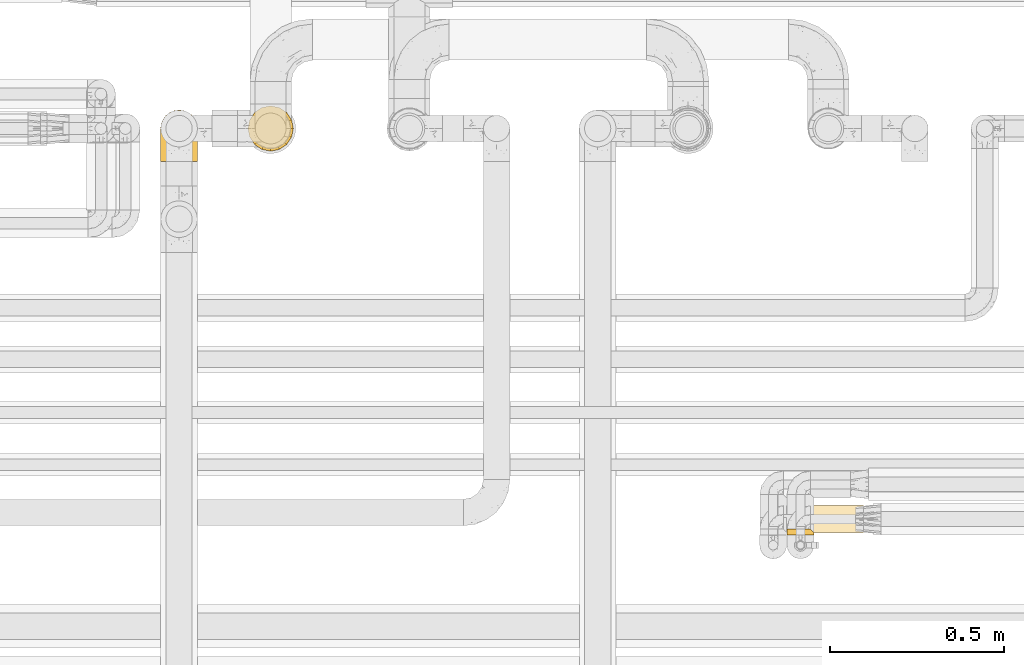
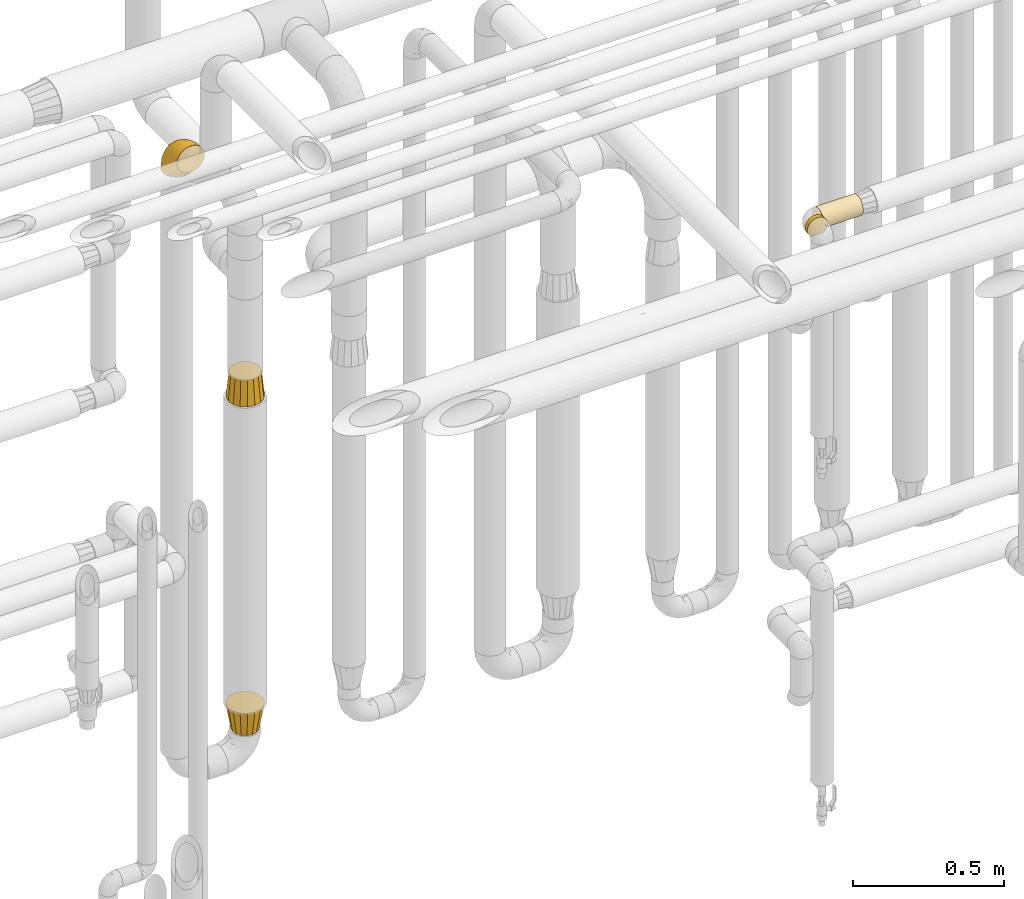
# One storey, part 463 of 827: 5 coverings.
"""IFC2X3 building model written with IfcOpenShell, lengths in millimetres."""

from ifc_helpers import new_model, entity, si_unit, converted_unit, derived_unit, direction, frame, origin, place, context, subcontext, project, spatial, faceted_brep, element, save


model = new_model("IFC2X3")

# Units and contexts
model_context = context("Model", 3, precision=0.01, world=origin(), true_north=direction((6.12303176911189e-17, 1.0)))
body_context = subcontext(model_context, "Body", "Model", "MODEL_VIEW")
ifc_project = project(units=[si_unit("LENGTHUNIT", "METRE", prefix="MILLI"), si_unit("AREAUNIT", "SQUARE_METRE"), si_unit("VOLUMEUNIT", "CUBIC_METRE"), converted_unit("PLANEANGLEUNIT", "DEGREE", entity("IfcRatioMeasure", 0.0174532925199433), si_unit("PLANEANGLEUNIT", "RADIAN"), dimensions=[0, 0, 0, 0, 0, 0, 0]), si_unit("MASSUNIT", "GRAM", prefix="KILO"), derived_unit("MASSDENSITYUNIT", [(si_unit("MASSUNIT", "GRAM", prefix="KILO"), 1), (si_unit("LENGTHUNIT", "METRE"), -3)]), derived_unit("MOMENTOFINERTIAUNIT", [(si_unit("LENGTHUNIT", "METRE"), 4)]), si_unit("TIMEUNIT", "SECOND"), si_unit("FREQUENCYUNIT", "HERTZ"), si_unit("THERMODYNAMICTEMPERATUREUNIT", "DEGREE_CELSIUS"), derived_unit("THERMALTRANSMITTANCEUNIT", [(si_unit("MASSUNIT", "GRAM", prefix="KILO"), 1), (si_unit("THERMODYNAMICTEMPERATUREUNIT", "KELVIN"), -1), (si_unit("TIMEUNIT", "SECOND"), -3)]), derived_unit("VOLUMETRICFLOWRATEUNIT", [(si_unit("LENGTHUNIT", "METRE"), 3), (si_unit("TIMEUNIT", "SECOND"), -1)]), derived_unit("MASSFLOWRATEUNIT", [(si_unit("MASSUNIT", "GRAM", prefix="KILO"), 1), (si_unit("TIMEUNIT", "SECOND"), -1)]), derived_unit("ROTATIONALFREQUENCYUNIT", [(si_unit("TIMEUNIT", "SECOND"), -1)]), si_unit("ELECTRICCURRENTUNIT", "AMPERE"), si_unit("ELECTRICVOLTAGEUNIT", "VOLT"), si_unit("POWERUNIT", "WATT"), si_unit("FORCEUNIT", "NEWTON", prefix="KILO"), si_unit("ILLUMINANCEUNIT", "LUX"), si_unit("LUMINOUSFLUXUNIT", "LUMEN"), si_unit("LUMINOUSINTENSITYUNIT", "CANDELA"), derived_unit("USERDEFINED", [(si_unit("MASSUNIT", "GRAM", prefix="KILO"), -1), (si_unit("LENGTHUNIT", "METRE"), -2), (si_unit("TIMEUNIT", "SECOND"), 3), (si_unit("LUMINOUSFLUXUNIT", "LUMEN"), 1)]), derived_unit("LINEARVELOCITYUNIT", [(si_unit("LENGTHUNIT", "METRE"), 1), (si_unit("TIMEUNIT", "SECOND"), -1)]), si_unit("PRESSUREUNIT", "PASCAL"), derived_unit("USERDEFINED", [(si_unit("LENGTHUNIT", "METRE"), -2), (si_unit("MASSUNIT", "GRAM", prefix="KILO"), 1), (si_unit("TIMEUNIT", "SECOND"), -2)]), derived_unit("LINEARFORCEUNIT", [(si_unit("MASSUNIT", "GRAM", prefix="KILO"), 1), (si_unit("LENGTHUNIT", "METRE"), 1), (si_unit("TIMEUNIT", "SECOND"), -2), (si_unit("LENGTHUNIT", "METRE"), -1)]), derived_unit("PLANARFORCEUNIT", [(si_unit("MASSUNIT", "GRAM", prefix="KILO"), 1), (si_unit("LENGTHUNIT", "METRE"), 1), (si_unit("TIMEUNIT", "SECOND"), -2), (si_unit("LENGTHUNIT", "METRE"), -2)])], contexts=[model_context])

# Site, building, storey
site_placement = place(None, origin())
site = spatial("IfcSite", under=ifc_project, at=site_placement, CompositionType="ELEMENT")
building_placement = place(site_placement, origin())
building = spatial("IfcBuilding", under=site, at=building_placement, CompositionType="ELEMENT")
storey_placement = place(building_placement, frame((0.0, 0.0, 28200.0)))
storey = spatial("IfcBuildingStorey", under=building, at=storey_placement, Name="08", CompositionType="ELEMENT", Elevation=28200.0)

# Coverings
covering_1_placement = place(storey_placement, frame((58597.1, 16339.84, 2610.0)))
element("IfcCovering", 1, at=covering_1_placement, inside=storey, Name=":ADSK_", ObjectType=":ADSK_", PredefinedType="INSULATION", context=body_context, shape_type="Brep", body=[
    faceted_brep([(153.01, 73.25, 20.8), (153.01, 77.09, 30.06), (153.01, 78.4, 40.0), (153.01, 77.09, 49.93), (153.01, 73.25, 59.2), (153.01, 67.15, 67.15), (153.01, 59.2, 73.25), (153.01, 49.93, 77.09), (153.01, 40.0, 78.4), (153.01, 30.06, 77.09), (153.01, 20.8, 73.25), (153.01, 12.84, 67.15), (153.01, 6.74, 59.2), (153.01, 2.9, 49.93), (153.01, 1.6, 40.0), (153.01, 2.9, 30.06), (153.01, 6.74, 20.8), (153.01, 12.84, 12.84), (153.01, 20.8, 6.74), (153.01, 30.06, 2.9), (153.01, 40.0, 1.6), (153.01, 49.93, 2.9), (153.01, 59.2, 6.74), (153.01, 67.15, 12.84), (1.6, 77.09, 30.06), (1.6, 73.25, 20.8), (1.6, 67.15, 12.84), (1.6, 59.2, 6.74), (1.6, 49.93, 2.9), (1.6, 40.0, 1.6), (1.6, 31.79, 2.48), (1.6, 23.98, 5.09), (1.6, 16.91, 9.31), (1.6, 10.9, 14.94), (1.6, 10.9, 65.05), (1.6, 16.91, 70.68), (1.6, 23.98, 74.9), (1.6, 31.79, 77.51), (1.6, 40.0, 78.4), (1.6, 49.93, 77.09), (1.6, 59.2, 73.25), (1.6, 67.15, 67.15), (1.6, 73.25, 59.2), (1.6, 77.09, 49.93), (1.6, 78.4, 40.0), (10.29, 2.2, 33.21), (8.5, 4.0, 26.63), (5.57, 6.92, 20.48), (10.9, 1.6, 40.0), (5.57, 6.92, 59.51), (8.5, 4.0, 53.36), (10.29, 2.2, 46.78)], [[[0, 1, 2, 3, 4, 5, 6, 7, 8, 9, 10, 11, 12, 13, 14, 15, 16, 17, 18, 19, 20, 21, 22, 23]], [[24, 25, 26, 27, 28, 29, 30, 31, 32, 33, 34, 35, 36, 37, 38, 39, 40, 41, 42, 43, 44]], [[45, 46, 15]], [[47, 33, 16]], [[46, 47, 16]], [[48, 45, 14]], [[14, 45, 15]], [[46, 16, 15]], [[33, 17, 16]], [[18, 32, 31]], [[19, 31, 30]], [[20, 30, 29]], [[17, 32, 18]], [[18, 31, 19]], [[30, 20, 19]], [[32, 17, 33]], [[21, 20, 29, 28]], [[22, 21, 28, 27]], [[27, 26, 23, 22]], [[1, 0, 25, 24]], [[2, 1, 24, 44]], [[26, 25, 0, 23]], [[3, 2, 44, 43]], [[4, 3, 43, 42]], [[42, 41, 5, 4]], [[7, 6, 40, 39]], [[8, 7, 39, 38]], [[41, 40, 6, 5]], [[8, 38, 37]], [[9, 37, 36]], [[10, 36, 35]], [[8, 37, 9]], [[9, 36, 10]], [[35, 11, 10]], [[35, 34, 11]], [[34, 49, 12]], [[50, 51, 13]], [[49, 50, 12]], [[12, 50, 13]], [[14, 13, 51]], [[48, 14, 51]], [[34, 12, 11]], [[33, 47, 46, 45, 48, 51, 50, 49, 34]]]),
])
covering_2_placement = place(storey_placement, frame((58529.6, 16332.34, 2610.0)))
element("IfcCovering", 2, at=covering_2_placement, inside=storey, Name=":ADSK_", ObjectType=":ADSK_", PredefinedType="INSULATION", context=body_context, shape_type="Brep", body=[
    faceted_brep([(12.84, 18.4, 67.15), (20.8, 18.4, 73.25), (30.06, 18.4, 77.09), (40.0, 18.4, 78.4), (48.2, 18.4, 77.51), (56.01, 18.4, 74.9), (63.08, 18.4, 70.68), (69.1, 18.4, 65.05), (69.1, 18.4, 14.94), (63.08, 18.4, 9.31), (56.01, 18.4, 5.09), (48.2, 18.4, 2.48), (40.0, 18.4, 1.6), (30.06, 18.4, 2.9), (20.8, 18.4, 6.74), (12.84, 18.4, 12.84), (6.74, 18.4, 20.8), (2.9, 18.4, 30.06), (1.6, 18.4, 40.0), (2.9, 18.4, 49.93), (6.74, 18.4, 59.2), (30.06, 1.6, 77.09), (20.8, 1.6, 73.25), (12.84, 1.6, 67.15), (6.74, 1.6, 59.2), (2.9, 1.6, 49.93), (1.6, 1.6, 40.0), (2.48, 1.6, 31.79), (5.09, 1.6, 23.98), (9.31, 1.6, 16.91), (14.94, 1.6, 10.9), (65.05, 1.6, 10.9), (70.68, 1.6, 16.91), (74.9, 1.6, 23.98), (77.51, 1.6, 31.79), (78.4, 1.6, 40.0), (77.09, 1.6, 49.93), (73.25, 1.6, 59.2), (67.15, 1.6, 67.15), (59.2, 1.6, 73.25), (49.93, 1.6, 77.09), (40.0, 1.6, 78.4), (77.79, 9.7, 33.21), (76.0, 11.5, 26.63), (73.07, 14.42, 20.48), (78.4, 9.1, 40.0), (59.51, 5.57, 6.92), (53.36, 8.5, 4.0), (46.78, 10.29, 2.2), (40.0, 10.9, 1.6), (33.21, 10.29, 2.2), (26.63, 8.5, 4.0), (20.48, 5.57, 6.92), (76.0, 11.5, 53.36), (77.79, 9.7, 46.78), (73.07, 14.42, 59.51)], [[[0, 1, 2, 3, 4, 5, 6, 7, 8, 9, 10, 11, 12, 13, 14, 15, 16, 17, 18, 19, 20]], [[21, 22, 23, 24, 25, 26, 27, 28, 29, 30, 31, 32, 33, 34, 35, 36, 37, 38, 39, 40, 41]], [[42, 35, 34]], [[34, 33, 43]], [[32, 44, 33]], [[42, 45, 35]], [[44, 43, 33]], [[8, 44, 32]], [[42, 34, 43]], [[32, 31, 8]], [[31, 46, 9]], [[47, 48, 11]], [[46, 47, 10]], [[9, 46, 10]], [[48, 12, 11]], [[11, 10, 47]], [[12, 48, 49]], [[31, 9, 8]], [[50, 51, 13]], [[14, 52, 15]], [[51, 52, 14]], [[49, 50, 12]], [[12, 50, 13]], [[51, 14, 13]], [[52, 30, 15]], [[16, 29, 28]], [[28, 27, 17]], [[26, 18, 27]], [[15, 29, 16]], [[17, 16, 28]], [[18, 17, 27]], [[29, 15, 30]], [[18, 26, 25, 19]], [[19, 25, 24, 20]], [[20, 24, 23, 0]], [[1, 22, 21, 2]], [[2, 21, 41, 3]], [[0, 23, 22, 1]], [[4, 41, 40]], [[40, 39, 5]], [[38, 6, 39]], [[3, 41, 4]], [[5, 4, 40]], [[6, 5, 39]], [[38, 7, 6]], [[53, 37, 36]], [[36, 35, 54]], [[45, 54, 35]], [[7, 38, 55]], [[54, 53, 36]], [[55, 37, 53]], [[55, 38, 37]], [[7, 55, 53, 54, 45, 42, 43, 44, 8]], [[52, 51, 50, 49, 48, 47, 46, 31, 30]]]),
])
covering_3_placement = place(storey_placement, frame((56983.47, 17433.4, 1790.74)))
element("IfcCovering", 3, at=covering_3_placement, inside=storey, Name=":ADSK_", ObjectType=":ADSK_", PredefinedType="INSULATION", context=body_context, shape_type="Brep", body=[
    faceted_brep([(11.6, 66.6, 102.0), (13.69, 56.07, 102.0), (15.78, 45.55, 102.0), (21.74, 36.63, 102.0), (27.7, 27.7, 102.0), (36.63, 21.74, 102.0), (45.55, 15.78, 102.0), (56.07, 13.69, 102.0), (66.6, 11.6, 102.0), (77.12, 13.69, 102.0), (87.64, 15.78, 102.0), (96.56, 21.74, 102.0), (105.49, 27.7, 102.0), (111.45, 36.63, 102.0), (117.41, 45.55, 102.0), (119.5, 56.07, 102.0), (121.6, 66.6, 102.0), (119.5, 77.12, 102.0), (117.41, 87.64, 102.0), (111.45, 96.56, 102.0), (105.49, 105.49, 102.0), (96.56, 111.45, 102.0), (87.64, 117.41, 102.0), (77.12, 119.5, 102.0), (66.6, 121.6, 102.0), (56.07, 119.5, 102.0), (45.55, 117.41, 102.0), (36.63, 111.45, 102.0), (27.7, 105.49, 102.0), (21.74, 96.56, 102.0), (15.78, 87.64, 102.0), (13.69, 77.12, 102.0), (91.47, 126.65, 0.0), (102.01, 119.6, 0.0), (112.56, 112.56, 0.0), (119.6, 102.01, 0.0), (126.65, 91.47, 0.0), (128.69, 81.18, 0.0), (131.6, 66.6, 0.0), (128.69, 52.01, 0.0), (126.65, 41.72, 0.0), (119.6, 31.18, 0.0), (112.56, 20.63, 0.0), (102.01, 13.59, 0.0), (91.47, 6.54, 0.0), (81.18, 4.5, 0.0), (66.6, 1.6, 0.0), (52.01, 4.5, 0.0), (41.72, 6.54, 0.0), (31.18, 13.59, 0.0), (20.63, 20.63, 0.0), (13.59, 31.18, 0.0), (6.54, 41.72, 0.0), (4.5, 52.01, 0.0), (1.6, 66.6, 0.0), (4.5, 81.18, 0.0), (6.54, 91.47, 0.0), (13.59, 102.01, 0.0), (20.63, 112.56, 0.0), (31.18, 119.6, 0.0), (41.72, 126.65, 0.0), (52.01, 128.69, 0.0), (66.6, 131.6, 0.0), (81.18, 128.69, 0.0)], [[[0, 1, 2, 3, 4, 5, 6, 7, 8, 9, 10, 11, 12, 13, 14, 15, 16, 17, 18, 19, 20, 21, 22, 23, 24, 25, 26, 27, 28, 29, 30, 31]], [[32, 33, 34, 35, 36, 37, 38, 39, 40, 41, 42, 43, 44, 45, 46, 47, 48, 49, 50, 51, 52, 53, 54, 55, 56, 57, 58, 59, 60, 61, 62, 63]], [[6, 48, 47, 46, 8, 7]], [[49, 48, 6, 5, 4, 50]], [[1, 0, 54, 53, 52, 2]], [[51, 50, 4, 3, 2, 52]], [[14, 40, 39, 38, 16, 15]], [[41, 40, 14, 13, 12, 42]], [[9, 8, 46, 45, 44, 10]], [[43, 42, 12, 11, 10, 44]], [[22, 32, 63, 62, 24, 23]], [[33, 32, 22, 21, 20, 34]], [[17, 16, 38, 37, 36, 18]], [[35, 34, 20, 19, 18, 36]], [[30, 56, 55, 54, 0, 31]], [[57, 56, 30, 29, 28, 58]], [[25, 24, 62, 61, 60, 26]], [[59, 58, 28, 27, 26, 60]]]),
])
covering_4_placement = place(storey_placement, frame((56983.47, 17433.4, 447.5)))
element("IfcCovering", 4, at=covering_4_placement, inside=storey, Name=":ADSK_", ObjectType=":ADSK_", PredefinedType="INSULATION", context=body_context, shape_type="Brep", body=[
    faceted_brep([(1.6, 66.6, 102.0), (4.38, 52.61, 102.0), (6.54, 41.72, 102.0), (13.59, 31.18, 102.0), (20.63, 20.63, 102.0), (31.18, 13.59, 102.0), (41.72, 6.54, 102.0), (52.61, 4.38, 102.0), (66.6, 1.6, 102.0), (80.58, 4.38, 102.0), (91.47, 6.54, 102.0), (102.01, 13.59, 102.0), (112.56, 20.63, 102.0), (119.6, 31.18, 102.0), (126.65, 41.72, 102.0), (128.81, 52.61, 102.0), (131.6, 66.6, 102.0), (128.81, 80.58, 102.0), (126.65, 91.47, 102.0), (119.6, 102.01, 102.0), (112.56, 112.56, 102.0), (102.01, 119.6, 102.0), (91.47, 126.65, 102.0), (80.58, 128.81, 102.0), (66.6, 131.6, 102.0), (52.61, 128.81, 102.0), (41.72, 126.65, 102.0), (31.18, 119.6, 102.0), (20.63, 112.56, 102.0), (13.59, 102.01, 102.0), (6.54, 91.47, 102.0), (4.38, 80.58, 102.0), (84.77, 110.48, 0.0), (92.48, 105.33, 0.0), (100.18, 100.18, 0.0), (105.33, 92.48, 0.0), (110.48, 84.77, 0.0), (112.29, 75.68, 0.0), (114.1, 66.6, 0.0), (112.29, 57.51, 0.0), (110.48, 48.42, 0.0), (105.33, 40.71, 0.0), (100.18, 33.01, 0.0), (92.48, 27.86, 0.0), (84.77, 22.71, 0.0), (75.68, 20.9, 0.0), (66.6, 19.1, 0.0), (57.51, 20.9, 0.0), (48.42, 22.71, 0.0), (40.71, 27.86, 0.0), (33.01, 33.01, 0.0), (27.86, 40.71, 0.0), (22.71, 48.42, 0.0), (20.9, 57.51, 0.0), (19.1, 66.6, 0.0), (20.9, 75.68, 0.0), (22.71, 84.77, 0.0), (27.86, 92.48, 0.0), (33.01, 100.18, 0.0), (40.71, 105.33, 0.0), (48.42, 110.48, 0.0), (57.51, 112.29, 0.0), (66.6, 114.1, 0.0), (75.68, 112.29, 0.0)], [[[0, 1, 2, 3, 4, 5, 6, 7, 8, 9, 10, 11, 12, 13, 14, 15, 16, 17, 18, 19, 20, 21, 22, 23, 24, 25, 26, 27, 28, 29, 30, 31]], [[32, 33, 34, 35, 36, 37, 38, 39, 40, 41, 42, 43, 44, 45, 46, 47, 48, 49, 50, 51, 52, 53, 54, 55, 56, 57, 58, 59, 60, 61, 62, 63]], [[52, 2, 1, 0, 54, 53]], [[50, 4, 3, 2, 52, 51]], [[8, 7, 6, 48, 47, 46]], [[4, 50, 49, 48, 6, 5]], [[44, 10, 9, 8, 46, 45]], [[42, 12, 11, 10, 44, 43]], [[16, 15, 14, 40, 39, 38]], [[12, 42, 41, 40, 14, 13]], [[36, 18, 17, 16, 38, 37]], [[34, 20, 19, 18, 36, 35]], [[24, 23, 22, 32, 63, 62]], [[20, 34, 33, 32, 22, 21]], [[60, 26, 25, 24, 62, 61]], [[58, 28, 27, 26, 60, 59]], [[0, 31, 30, 56, 55, 54]], [[28, 58, 57, 56, 30, 29]]]),
])
covering_5_placement = place(storey_placement, frame((56732.74, 17403.4, 2803.4)))
element("IfcCovering", 5, at=covering_5_placement, inside=storey, Name=":ADSK_", ObjectType=":ADSK_", PredefinedType="INSULATION", context=body_context, shape_type="Brep", body=[
    faceted_brep([(66.44, 1.6, 148.32), (54.65, 1.6, 149.65), (42.84, 1.6, 148.31), (31.62, 1.6, 144.39), (21.56, 1.6, 138.06), (13.16, 1.6, 129.66), (6.84, 1.6, 119.6), (2.92, 1.6, 108.39), (1.6, 1.6, 96.6), (2.93, 1.6, 84.79), (6.85, 1.6, 73.57), (13.18, 1.6, 63.51), (21.58, 1.6, 55.11), (31.64, 1.6, 48.79), (42.85, 1.6, 44.87), (54.65, 1.6, 43.55), (66.46, 1.6, 44.88), (77.67, 1.6, 48.8), (87.73, 1.6, 55.13), (96.13, 1.6, 63.53), (102.45, 1.6, 73.59), (106.37, 1.6, 84.8), (107.7, 1.6, 96.6), (106.36, 1.6, 108.41), (102.44, 1.6, 119.62), (96.11, 1.6, 129.68), (87.71, 1.6, 138.08), (77.65, 1.6, 144.4), (40.91, 45.35, 1.6), (28.12, 50.65, 1.6), (17.13, 59.08, 1.6), (8.7, 70.07, 1.6), (3.4, 82.86, 1.6), (1.6, 96.6, 1.6), (3.4, 110.33, 1.6), (8.7, 123.12, 1.6), (17.13, 134.11, 1.6), (28.12, 142.54, 1.6), (40.91, 147.84, 1.6), (54.65, 149.65, 1.6), (68.38, 147.84, 1.6), (81.17, 142.54, 1.6), (92.16, 134.11, 1.6), (100.59, 123.12, 1.6), (105.89, 110.33, 1.6), (107.7, 96.6, 1.6), (105.89, 82.86, 1.6), (100.59, 70.07, 1.6), (92.16, 59.08, 1.6), (81.17, 50.65, 1.6), (68.38, 45.35, 1.6), (54.65, 43.55, 1.6), (85.53, 137.19, 27.97), (73.42, 141.79, 37.09), (83.77, 128.89, 58.27), (64.22, 146.54, 27.13), (54.65, 144.6, 39.91), (96.72, 69.77, 109.11), (93.36, 94.41, 94.41), (84.47, 87.22, 110.94), (71.37, 117.2, 89.69), (54.65, 129.81, 75.62), (54.65, 106.28, 106.28), (103.47, 101.45, 60.12), (100.91, 115.81, 41.41), (99.1, 109.14, 63.22), (105.43, 107.65, 32.05), (106.79, 93.36, 52.13), (89.81, 59.44, 123.27), (79.59, 63.23, 129.32), (81.29, 35.59, 138.3), (74.01, 132.3, 62.95), (64.14, 138.41, 55.89), (94.75, 126.28, 37.4), (54.65, 39.91, 144.6), (70.74, 37.44, 142.66), (68.3, 90.35, 117.85), (66.05, 65.0, 134.01), (100.73, 85.4, 89.25), (106.78, 26.66, 103.34), (103.6, 29.88, 113.52), (107.7, 78.45, 57.43), (107.7, 85.2, 44.19), (107.7, 91.95, 30.95), (106.07, 77.98, 77.98), (90.59, 29.55, 132.66), (97.43, 41.42, 121.52), (84.51, 111.13, 86.93), (93.3, 114.67, 68.4), (107.7, 57.43, 78.45), (107.7, 67.94, 67.94), (107.7, 14.64, 94.53), (107.7, 30.95, 91.95), (106.79, 52.13, 93.36), (107.7, 44.19, 85.2), (103.47, 60.12, 101.45), (54.65, 75.62, 129.81), (107.7, 94.27, 16.27), (76.99, 24.59, 42.46), (84.28, 34.69, 40.4), (91.11, 31.15, 49.71), (106.26, 75.18, 39.4), (102.6, 67.55, 31.26), (106.08, 79.36, 27.7), (106.56, 84.32, 16.7), (105.36, 40.81, 70.67), (106.74, 29.93, 81.69), (101.59, 70.24, 16.68), (54.65, 37.93, 22.57), (54.65, 40.15, 14.26), (67.71, 42.1, 17.68), (91.36, 55.38, 19.58), (94.33, 52.17, 33.49), (87.1, 44.32, 33.01), (65.84, 19.85, 40.69), (54.65, 14.26, 40.15), (54.65, 22.57, 37.93), (68.92, 34.17, 31.04), (100.82, 54.85, 45.29), (79.83, 44.63, 23.55), (77.13, 47.52, 11.36), (105.9, 59.1, 59.1), (101.53, 44.11, 57.42), (106.72, 53.21, 68.96), (97.75, 62.86, 20.38), (103.08, 20.58, 72.46), (106.39, 15.79, 83.66), (98.1, 27.67, 60.66), (95.02, 13.49, 61.01), (86.9, 18.04, 51.85), (74.42, 12.44, 46.07), (54.65, 30.25, 30.25), (105.28, 66.71, 46.65), (92.87, 42.52, 43.0), (17.93, 55.38, 19.58), (6.22, 20.57, 72.44), (41.58, 42.11, 17.67), (1.6, 57.43, 78.45), (2.57, 53.22, 68.97), (3.94, 40.81, 70.65), (43.46, 19.85, 40.69), (32.32, 24.58, 42.45), (40.38, 34.16, 31.04), (16.44, 42.5, 42.99), (8.47, 54.93, 45.18), (15.01, 52.13, 33.46), (11.21, 27.66, 60.64), (7.78, 44.12, 57.37), (1.6, 78.45, 57.43), (1.6, 85.2, 44.19), (3.04, 75.17, 39.35), (1.6, 94.27, 16.27), (2.73, 84.32, 16.7), (1.6, 30.95, 91.95), (1.6, 44.19, 85.2), (2.55, 29.98, 81.68), (3.98, 66.78, 46.68), (6.69, 67.55, 31.26), (7.7, 70.24, 16.68), (3.21, 79.36, 27.7), (14.28, 13.48, 60.99), (22.42, 18.03, 51.84), (25.02, 34.66, 40.41), (18.18, 31.14, 49.72), (34.89, 12.43, 46.06), (1.6, 14.64, 94.53), (32.17, 47.52, 11.35), (22.23, 44.28, 33.02), (2.91, 15.8, 83.65), (11.54, 62.86, 20.38), (1.6, 67.94, 67.94), (29.46, 44.64, 23.53), (3.38, 59.12, 59.12), (1.6, 91.95, 30.95), (25.52, 128.89, 58.27), (23.76, 137.19, 27.97), (14.54, 126.28, 37.4), (8.38, 115.81, 41.41), (45.07, 146.53, 27.21), (35.87, 141.79, 37.09), (45.14, 139.45, 53.2), (2.5, 93.36, 52.13), (2.51, 26.67, 103.34), (5.68, 29.87, 113.5), (5.82, 60.12, 101.45), (15.93, 94.41, 94.41), (12.54, 69.76, 109.08), (24.81, 87.19, 110.95), (2.5, 52.13, 93.36), (3.22, 77.98, 77.98), (3.86, 107.65, 32.05), (35.85, 131.74, 64.63), (19.47, 59.44, 123.25), (18.68, 29.54, 132.65), (29.68, 63.2, 129.32), (27.95, 27.9, 139.96), (40.99, 90.35, 117.85), (37.92, 117.2, 89.69), (11.85, 41.39, 121.51), (10.19, 109.14, 63.23), (8.55, 85.46, 89.17), (38.53, 37.43, 142.66), (15.99, 114.67, 68.4), (24.79, 111.12, 86.94), (5.82, 101.45, 60.12), (40.56, 65.16, 133.2)], [[[0, 1, 2, 3, 4, 5, 6, 7, 8, 9, 10, 11, 12, 13, 14, 15, 16, 17, 18, 19, 20, 21, 22, 23, 24, 25, 26, 27]], [[28, 29, 30, 31, 32, 33, 34, 35, 36, 37, 38, 39, 40, 41, 42, 43, 44, 45, 46, 47, 48, 49, 50, 51]], [[52, 53, 54]], [[55, 39, 56]], [[57, 58, 59]], [[60, 61, 62]], [[63, 64, 65]], [[66, 63, 67]], [[68, 69, 70]], [[53, 71, 54]], [[41, 40, 53]], [[53, 72, 71]], [[73, 42, 52]], [[42, 41, 52]], [[74, 0, 75]], [[69, 76, 77]], [[43, 73, 64]], [[45, 44, 66]], [[57, 78, 58]], [[23, 79, 80]], [[67, 81, 82, 83]], [[67, 84, 81]], [[24, 23, 80]], [[25, 85, 26]], [[86, 85, 25]], [[42, 73, 43]], [[0, 27, 75]], [[25, 24, 86]], [[70, 26, 85]], [[0, 74, 1]], [[68, 85, 86]], [[66, 64, 63]], [[60, 59, 87]], [[54, 87, 88]], [[76, 60, 62]], [[84, 89, 90, 81]], [[79, 22, 91, 92]], [[77, 74, 75]], [[93, 92, 94, 89]], [[80, 86, 24]], [[40, 55, 53]], [[76, 59, 60]], [[93, 84, 95]], [[76, 62, 96]], [[55, 72, 53]], [[70, 27, 26]], [[75, 70, 69]], [[78, 84, 63]], [[93, 79, 92]], [[95, 86, 80]], [[77, 76, 96]], [[59, 69, 68]], [[57, 68, 86]], [[68, 57, 59]], [[59, 58, 87]], [[76, 69, 59]], [[88, 87, 58]], [[87, 54, 71]], [[86, 95, 57]], [[78, 57, 95]], [[84, 78, 95]], [[78, 63, 65]], [[58, 78, 65]], [[54, 88, 73]], [[84, 93, 89]], [[79, 95, 80]], [[79, 93, 95]], [[22, 79, 23]], [[66, 83, 97, 45]], [[84, 67, 63]], [[83, 66, 67]], [[64, 44, 43]], [[64, 66, 44]], [[65, 73, 88]], [[53, 52, 41]], [[73, 52, 54]], [[73, 65, 64]], [[65, 88, 58]], [[39, 55, 40]], [[72, 55, 56]], [[56, 61, 72]], [[60, 72, 61]], [[72, 60, 71]], [[87, 71, 60]], [[27, 70, 75]], [[68, 70, 85]], [[74, 77, 96]], [[69, 77, 75]], [[98, 99, 100]], [[46, 45, 97]], [[101, 102, 103]], [[103, 104, 83]], [[105, 94, 106]], [[107, 103, 102]], [[108, 109, 51, 110]], [[111, 112, 113]], [[114, 115, 116]], [[47, 104, 107]], [[110, 117, 108]], [[49, 48, 111]], [[102, 118, 112]], [[119, 120, 111]], [[50, 49, 120]], [[121, 122, 118]], [[105, 123, 89]], [[124, 48, 107]], [[20, 19, 125]], [[121, 81, 90]], [[117, 119, 99]], [[21, 20, 126]], [[22, 21, 91]], [[105, 125, 127]], [[110, 51, 50]], [[19, 128, 125]], [[16, 15, 115]], [[129, 98, 100]], [[126, 91, 21]], [[128, 129, 127]], [[122, 123, 105]], [[114, 117, 98]], [[17, 16, 130]], [[18, 128, 19]], [[129, 18, 17]], [[125, 106, 126]], [[115, 114, 16]], [[130, 129, 17]], [[114, 98, 130]], [[117, 116, 131, 108]], [[99, 119, 113]], [[122, 121, 123]], [[92, 126, 106]], [[105, 127, 122]], [[132, 121, 118]], [[114, 130, 16]], [[129, 130, 98]], [[50, 120, 110]], [[129, 128, 18]], [[125, 128, 127]], [[125, 126, 20]], [[91, 126, 92]], [[105, 89, 94]], [[105, 106, 125]], [[94, 92, 106]], [[100, 122, 127]], [[118, 122, 133]], [[112, 118, 133]], [[132, 118, 102]], [[132, 102, 101]], [[81, 121, 132]], [[82, 103, 83]], [[132, 101, 81]], [[104, 47, 46]], [[124, 107, 102]], [[48, 47, 107]], [[113, 112, 133]], [[112, 111, 124]], [[99, 113, 133]], [[111, 113, 119]], [[99, 133, 100]], [[117, 99, 98]], [[122, 100, 133]], [[127, 129, 100]], [[103, 82, 101]], [[81, 101, 82]], [[112, 124, 102]], [[48, 124, 111]], [[104, 103, 107]], [[46, 97, 104]], [[111, 120, 49]], [[83, 104, 97]], [[110, 120, 119]], [[117, 110, 119]], [[116, 117, 114]], [[123, 90, 89]], [[90, 123, 121]], [[30, 29, 134]], [[11, 10, 135]], [[51, 109, 108, 136]], [[137, 138, 139]], [[140, 141, 142]], [[143, 144, 145]], [[146, 139, 147]], [[148, 149, 150]], [[151, 32, 152]], [[153, 154, 155]], [[156, 150, 157]], [[158, 157, 159]], [[108, 142, 136]], [[31, 158, 152]], [[160, 161, 12]], [[162, 163, 143]], [[140, 142, 116]], [[142, 141, 162]], [[14, 164, 140]], [[14, 140, 115]], [[9, 8, 165]], [[160, 12, 11]], [[141, 164, 161]], [[13, 12, 161]], [[14, 115, 15]], [[28, 166, 29]], [[135, 139, 146]], [[141, 163, 162]], [[135, 146, 160]], [[143, 167, 162]], [[29, 166, 134]], [[116, 142, 108, 131]], [[165, 153, 168]], [[10, 9, 168]], [[168, 135, 10]], [[138, 147, 139]], [[158, 169, 157]], [[14, 13, 164]], [[116, 115, 140]], [[145, 167, 143]], [[135, 160, 11]], [[168, 153, 155]], [[138, 137, 170]], [[157, 144, 156]], [[147, 144, 143]], [[161, 164, 13]], [[140, 164, 141]], [[142, 171, 136]], [[136, 171, 166]], [[161, 160, 146]], [[165, 168, 9]], [[155, 139, 135]], [[139, 154, 137]], [[168, 155, 135]], [[139, 155, 154]], [[144, 147, 172]], [[163, 147, 143]], [[156, 144, 172]], [[157, 169, 145]], [[172, 148, 156]], [[173, 159, 149]], [[159, 157, 150]], [[152, 159, 173]], [[159, 152, 158]], [[31, 30, 158]], [[169, 30, 134]], [[157, 145, 144]], [[167, 134, 171]], [[134, 167, 145]], [[171, 142, 162]], [[162, 167, 171]], [[163, 141, 161]], [[161, 146, 163]], [[147, 163, 146]], [[148, 150, 156]], [[149, 159, 150]], [[30, 169, 158]], [[145, 169, 134]], [[151, 33, 32]], [[31, 152, 32]], [[152, 173, 151]], [[28, 51, 136]], [[134, 166, 171]], [[28, 136, 166]], [[138, 170, 172]], [[147, 138, 172]], [[148, 172, 170]], [[174, 175, 176]], [[35, 34, 177]], [[178, 179, 180]], [[181, 173, 149, 148]], [[182, 183, 184]], [[185, 186, 187]], [[188, 189, 137]], [[190, 33, 151, 173]], [[191, 179, 174]], [[34, 190, 177]], [[39, 38, 178]], [[192, 193, 194]], [[4, 3, 195]], [[175, 179, 37]], [[38, 37, 179]], [[35, 176, 36]], [[196, 62, 197]], [[181, 190, 173]], [[37, 36, 175]], [[183, 6, 198]], [[189, 148, 170, 137]], [[185, 199, 200]], [[3, 2, 201]], [[202, 185, 203]], [[8, 7, 182]], [[200, 184, 186]], [[183, 7, 6]], [[181, 189, 204]], [[200, 189, 184]], [[5, 198, 6]], [[187, 203, 185]], [[195, 3, 201]], [[205, 196, 194]], [[62, 61, 197]], [[186, 198, 192]], [[180, 179, 191]], [[2, 1, 74]], [[198, 193, 192]], [[193, 5, 4]], [[194, 193, 195]], [[2, 74, 201]], [[5, 193, 198]], [[205, 74, 96]], [[188, 137, 154, 153]], [[62, 196, 96]], [[56, 178, 180]], [[198, 184, 183]], [[184, 188, 182]], [[203, 197, 191]], [[205, 194, 201]], [[187, 192, 194]], [[192, 187, 186]], [[194, 196, 187]], [[197, 187, 196]], [[197, 203, 187]], [[202, 174, 176]], [[200, 186, 185]], [[184, 198, 186]], [[199, 185, 202]], [[189, 200, 204]], [[174, 202, 203]], [[176, 177, 199]], [[189, 181, 148]], [[190, 181, 204]], [[190, 204, 177]], [[190, 34, 33]], [[188, 153, 182]], [[189, 188, 184]], [[182, 153, 165, 8]], [[183, 182, 7]], [[199, 177, 204]], [[35, 177, 176]], [[176, 175, 36]], [[179, 175, 174]], [[200, 199, 204]], [[176, 199, 202]], [[203, 191, 174]], [[180, 197, 61]], [[197, 180, 191]], [[61, 56, 180]], [[39, 178, 56]], [[38, 179, 178]], [[194, 195, 201]], [[4, 195, 193]], [[74, 205, 201]], [[96, 196, 205]]]),
])

save(model, "model.ifc")
